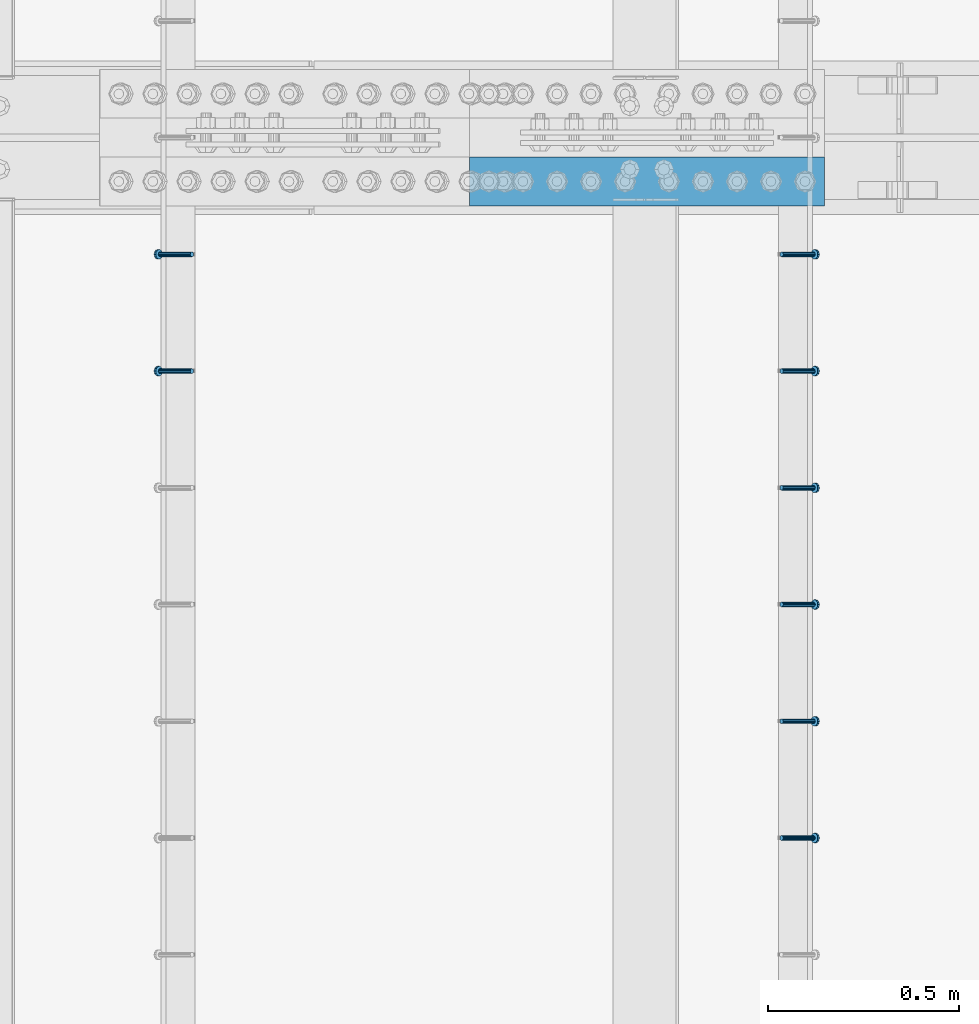
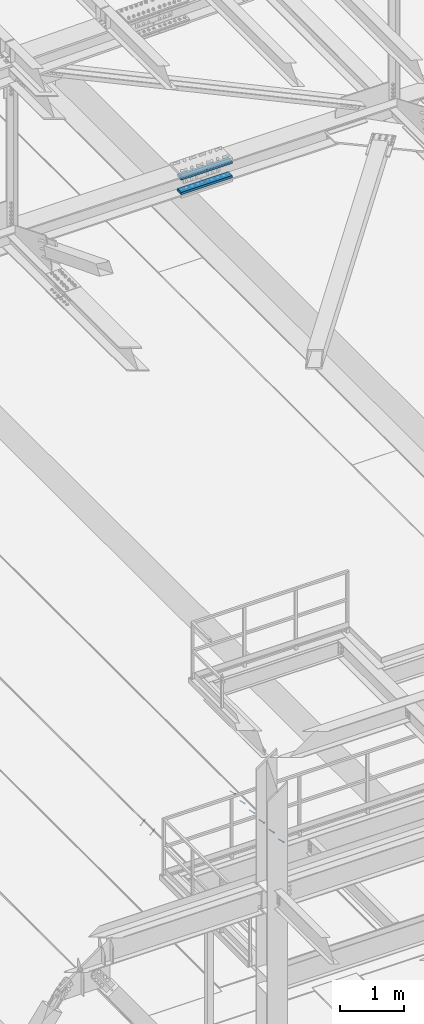
# One storey, part 2229 of 3843: 8 members, 2 beams, 3 elements without a shape of their own.
"""IFC2X3 building model written with IfcOpenShell, lengths in millimetres."""

from ifc_helpers import new_model, si_unit, frame, origin_with_axes, place, context, subcontext, project, spatial, faceted_brep, material, type_object, element, aggregate, save


model = new_model("IFC2X3")

# Units and contexts
model_context = context("Model", 3, precision=1e-05, world=origin_with_axes())
body_context = subcontext(model_context, "Body", "Model", "MODEL_VIEW")
ifc_project = project(units=[si_unit("LENGTHUNIT", "METRE", prefix="MILLI"), si_unit("AREAUNIT", "SQUARE_METRE"), si_unit("VOLUMEUNIT", "CUBIC_METRE"), si_unit("MASSUNIT", "GRAM", prefix="KILO"), si_unit("TIMEUNIT", "SECOND"), si_unit("PLANEANGLEUNIT", "RADIAN"), si_unit("SOLIDANGLEUNIT", "STERADIAN"), si_unit("THERMODYNAMICTEMPERATUREUNIT", "DEGREE_CELSIUS"), si_unit("LUMINOUSINTENSITYUNIT", "LUMEN")], contexts=[model_context])

# Site, building, storey
site_placement = place(None, origin_with_axes())
site = spatial("IfcSite", under=ifc_project, at=site_placement, CompositionType="ELEMENT")
building_placement = place(site_placement, origin_with_axes())
building = spatial("IfcBuilding", under=site, at=building_placement, Name="Undefined", CompositionType="ELEMENT")
storey_placement = place(building_placement, origin_with_axes())
storey = spatial("IfcBuildingStorey", under=building, at=storey_placement, Name="Undefined", CompositionType="ELEMENT", Elevation=0.0)

# Assembly, members
assembly_1_placement = place(storey_placement, origin_with_axes())
assembly_1 = element("IfcElementAssembly", 1, at=assembly_1_placement, inside=storey, Name="EMBED_ANGLE", AssemblyPlace="NOTDEFINED", PredefinedType="RIGID_FRAME")
ifc_material_1 = material(Name="STEEL/A108")
member_type = type_object("IfcMemberType", PredefinedType="NOTDEFINED")
member_1_placement = place(assembly_1_placement, frame((52815.2360419921, 32016.826609375, 30446.6625), z_axis=(0.0, 1.0, 0.0), x_axis=(0.707106781186548, 0.0, -0.707106781186548)))
member_1 = element("IfcMember", 2, at=member_1_placement, type_object=member_type, material=ifc_material_1, Name="HEADED STUD ANCHOR", context=body_context, shape_type="Brep", body=[
    faceted_brep([(7.27595761418343e-12, -3.18000006675175, 5.5), (0.0, -5.49999999998363, 3.1800000667572), (118.110000000976, -5.49999999999091, 3.1800000667572), (118.110000000983, -3.18000006675175, 5.5), (0.0, -6.3499999046162, 0.0), (118.110000000968, -6.34999990461256, 0.0), (0.0, -5.49999999998363, -3.1800000667572), (118.110000000976, -5.49999999999091, -3.1800000667572), (7.27595761418343e-12, -3.18000006675175, -5.5), (118.110000000983, -3.18000006675175, -5.5), (7.27595761418343e-12, -1.81898940354586e-12, -6.34999990463257), (118.110000000968, -1.81898940354586e-12, -6.34999990463257), (0.0, 3.18000006675175, -5.5), (118.110000000968, 3.18000006674811, -5.5), (7.27595761418343e-12, 5.49999999998363, -3.1800000667572), (118.110000000983, 5.49999999998363, -3.1800000667572), (7.27595761418343e-12, 6.3499999046162, 0.0), (118.110000000976, 6.34999990461256, 0.0), (7.27595761418343e-12, 5.49999999998363, 3.1800000667572), (118.110000000983, 5.49999999998363, 3.1800000667572), (0.0, 3.18000006675175, 5.5), (118.110000000968, 3.18000006674811, 5.5), (7.27595761418343e-12, -1.81898940354586e-12, 6.34999990463257), (118.110000000968, -1.81898940354586e-12, 6.34999990463257), (120.650000000991, -10.9899997710909, 6.34999990463257), (120.650000000998, -6.34000015257152, 10.9899997711182), (120.650000000991, -12.6999998092379, 0.0), (120.650000000991, -10.9899997710909, -6.34999990463257), (120.650000000998, -6.34000015257152, -10.9899997711182), (120.650000000991, -1.81898940354586e-12, -12.6899995803833), (120.650000000991, 6.34000015257152, -10.9899997711182), (120.650000000998, 10.9899997710909, -6.34999990463257), (120.650000000991, 12.6999998092342, 0.0), (120.650000000998, 10.9899997710909, 6.34999990463257), (120.650000000991, 6.34000015257152, 10.9899997711182), (120.650000000991, -1.81898940354586e-12, 12.6899995803833), (127.000000001048, -10.9899997710945, 6.34999990463257), (127.000000001048, -6.34000015257152, 10.9899997711182), (127.000000001048, -12.6999998092342, 0.0), (127.000000001048, -10.9899997710945, -6.34999990463257), (127.000000001048, -6.34000015257152, -10.9899997711182), (127.000000001048, 1.81898940354586e-12, -12.6899995803833), (127.000000001048, 6.34000015256788, -10.9899997711182), (127.000000001048, 10.9899997710909, -6.34999990463257), (127.000000001048, 12.6999998092379, 0.0), (127.000000001048, 10.9899997710909, 6.34999990463257), (127.000000001048, 6.34000015256788, 10.9899997711182), (127.000000001048, 1.81898940354586e-12, 12.6899995803833)], [[[0, 1, 2, 3]], [[1, 4, 5, 2]], [[4, 6, 7, 5]], [[6, 8, 9, 7]], [[8, 10, 11, 9]], [[10, 12, 13, 11]], [[12, 14, 15, 13]], [[14, 16, 17, 15]], [[16, 18, 19, 17]], [[18, 20, 21, 19]], [[20, 22, 23, 21]], [[22, 0, 3, 23]], [[22, 20, 18, 16, 14, 12, 10, 8, 6, 4, 1, 0]], [[3, 2, 24, 25]], [[2, 5, 26, 24]], [[5, 7, 27, 26]], [[7, 9, 28, 27]], [[9, 11, 29, 28]], [[11, 13, 30, 29]], [[13, 15, 31, 30]], [[15, 17, 32, 31]], [[17, 19, 33, 32]], [[19, 21, 34, 33]], [[21, 23, 35, 34]], [[23, 3, 25, 35]], [[25, 24, 36, 37]], [[24, 26, 38, 36]], [[26, 27, 39, 38]], [[27, 28, 40, 39]], [[28, 29, 41, 40]], [[29, 30, 42, 41]], [[30, 31, 43, 42]], [[31, 32, 44, 43]], [[32, 33, 45, 44]], [[33, 34, 46, 45]], [[34, 35, 47, 46]], [[35, 25, 37, 47]], [[38, 39, 40, 41, 42, 43, 44, 45, 46, 47, 37, 36]]]),
])
member_2_placement = place(assembly_1_placement, frame((52815.2360419921, 32321.626609375, 30446.6625), z_axis=(0.0, 1.0, 0.0), x_axis=(0.707106781186548, 0.0, -0.707106781186548)))
member_2 = element("IfcMember", 3, at=member_2_placement, type_object=member_type, material=ifc_material_1, Name="HEADED STUD ANCHOR", context=body_context, shape_type="Brep", body=[
    faceted_brep([(7.27595761418343e-12, -3.18000006675175, 5.5), (0.0, -5.49999999998363, 3.1800000667572), (118.110000000976, -5.49999999999091, 3.1800000667572), (118.110000000983, -3.18000006675175, 5.5), (0.0, -6.3499999046162, 0.0), (118.110000000968, -6.34999990461256, 0.0), (0.0, -5.49999999998363, -3.1800000667572), (118.110000000976, -5.49999999999091, -3.1800000667572), (7.27595761418343e-12, -3.18000006675175, -5.5), (118.110000000983, -3.18000006675175, -5.5), (7.27595761418343e-12, -1.81898940354586e-12, -6.34999990463257), (118.110000000968, -1.81898940354586e-12, -6.34999990463257), (0.0, 3.18000006675175, -5.5), (118.110000000968, 3.18000006674811, -5.5), (7.27595761418343e-12, 5.49999999998363, -3.1800000667572), (118.110000000983, 5.49999999998363, -3.1800000667572), (7.27595761418343e-12, 6.3499999046162, 0.0), (118.110000000976, 6.34999990461256, 0.0), (7.27595761418343e-12, 5.49999999998363, 3.1800000667572), (118.110000000983, 5.49999999998363, 3.1800000667572), (0.0, 3.18000006675175, 5.5), (118.110000000968, 3.18000006674811, 5.5), (7.27595761418343e-12, -1.81898940354586e-12, 6.34999990463257), (118.110000000968, -1.81898940354586e-12, 6.34999990463257), (120.650000000991, -10.9899997710909, 6.34999990463257), (120.650000000998, -6.34000015257152, 10.9899997711182), (120.650000000991, -12.6999998092379, 0.0), (120.650000000991, -10.9899997710909, -6.34999990463257), (120.650000000998, -6.34000015257152, -10.9899997711182), (120.650000000991, -1.81898940354586e-12, -12.6899995803833), (120.650000000991, 6.34000015257152, -10.9899997711182), (120.650000000998, 10.9899997710909, -6.34999990463257), (120.650000000991, 12.6999998092342, 0.0), (120.650000000998, 10.9899997710909, 6.34999990463257), (120.650000000991, 6.34000015257152, 10.9899997711182), (120.650000000991, -1.81898940354586e-12, 12.6899995803833), (127.000000001048, -10.9899997710945, 6.34999990463257), (127.000000001048, -6.34000015257152, 10.9899997711182), (127.000000001048, -12.6999998092342, 0.0), (127.000000001048, -10.9899997710945, -6.34999990463257), (127.000000001048, -6.34000015257152, -10.9899997711182), (127.000000001048, 1.81898940354586e-12, -12.6899995803833), (127.000000001048, 6.34000015256788, -10.9899997711182), (127.000000001048, 10.9899997710909, -6.34999990463257), (127.000000001048, 12.6999998092379, 0.0), (127.000000001048, 10.9899997710909, 6.34999990463257), (127.000000001048, 6.34000015256788, 10.9899997711182), (127.000000001048, 1.81898940354586e-12, 12.6899995803833)], [[[0, 1, 2, 3]], [[1, 4, 5, 2]], [[4, 6, 7, 5]], [[6, 8, 9, 7]], [[8, 10, 11, 9]], [[10, 12, 13, 11]], [[12, 14, 15, 13]], [[14, 16, 17, 15]], [[16, 18, 19, 17]], [[18, 20, 21, 19]], [[20, 22, 23, 21]], [[22, 0, 3, 23]], [[22, 20, 18, 16, 14, 12, 10, 8, 6, 4, 1, 0]], [[3, 2, 24, 25]], [[2, 5, 26, 24]], [[5, 7, 27, 26]], [[7, 9, 28, 27]], [[9, 11, 29, 28]], [[11, 13, 30, 29]], [[13, 15, 31, 30]], [[15, 17, 32, 31]], [[17, 19, 33, 32]], [[19, 21, 34, 33]], [[21, 23, 35, 34]], [[23, 3, 25, 35]], [[25, 24, 36, 37]], [[24, 26, 38, 36]], [[26, 27, 39, 38]], [[27, 28, 40, 39]], [[28, 29, 41, 40]], [[29, 30, 42, 41]], [[30, 31, 43, 42]], [[31, 32, 44, 43]], [[32, 33, 45, 44]], [[33, 34, 46, 45]], [[34, 35, 47, 46]], [[35, 25, 37, 47]], [[38, 39, 40, 41, 42, 43, 44, 45, 46, 47, 37, 36]]]),
])
member_3_placement = place(assembly_1_placement, frame((52815.2360419921, 32626.426609375, 30446.6625), z_axis=(0.0, 1.0, 0.0), x_axis=(0.707106781186548, 0.0, -0.707106781186548)))
member_3 = element("IfcMember", 4, at=member_3_placement, type_object=member_type, material=ifc_material_1, Name="HEADED STUD ANCHOR", context=body_context, shape_type="Brep", body=[
    faceted_brep([(7.27595761418343e-12, -3.18000006675175, 5.5), (0.0, -5.49999999998363, 3.1800000667572), (118.110000000976, -5.49999999999091, 3.1800000667572), (118.110000000983, -3.18000006675175, 5.5), (0.0, -6.3499999046162, 0.0), (118.110000000968, -6.34999990461256, 0.0), (0.0, -5.49999999998363, -3.1800000667572), (118.110000000976, -5.49999999999091, -3.1800000667572), (7.27595761418343e-12, -3.18000006675175, -5.5), (118.110000000983, -3.18000006675175, -5.5), (7.27595761418343e-12, -1.81898940354586e-12, -6.34999990463257), (118.110000000968, -1.81898940354586e-12, -6.34999990463257), (0.0, 3.18000006675175, -5.5), (118.110000000968, 3.18000006674811, -5.5), (7.27595761418343e-12, 5.49999999998363, -3.1800000667572), (118.110000000983, 5.49999999998363, -3.1800000667572), (7.27595761418343e-12, 6.3499999046162, 0.0), (118.110000000976, 6.34999990461256, 0.0), (7.27595761418343e-12, 5.49999999998363, 3.1800000667572), (118.110000000983, 5.49999999998363, 3.1800000667572), (0.0, 3.18000006675175, 5.5), (118.110000000968, 3.18000006674811, 5.5), (7.27595761418343e-12, -1.81898940354586e-12, 6.34999990463257), (118.110000000968, -1.81898940354586e-12, 6.34999990463257), (120.650000000991, -10.9899997710909, 6.34999990463257), (120.650000000998, -6.34000015257152, 10.9899997711182), (120.650000000991, -12.6999998092379, 0.0), (120.650000000991, -10.9899997710909, -6.34999990463257), (120.650000000998, -6.34000015257152, -10.9899997711182), (120.650000000991, -1.81898940354586e-12, -12.6899995803833), (120.650000000991, 6.34000015257152, -10.9899997711182), (120.650000000998, 10.9899997710909, -6.34999990463257), (120.650000000991, 12.6999998092342, 0.0), (120.650000000998, 10.9899997710909, 6.34999990463257), (120.650000000991, 6.34000015257152, 10.9899997711182), (120.650000000991, -1.81898940354586e-12, 12.6899995803833), (127.000000001048, -10.9899997710945, 6.34999990463257), (127.000000001048, -6.34000015257152, 10.9899997711182), (127.000000001048, -12.6999998092342, 0.0), (127.000000001048, -10.9899997710945, -6.34999990463257), (127.000000001048, -6.34000015257152, -10.9899997711182), (127.000000001048, 1.81898940354586e-12, -12.6899995803833), (127.000000001048, 6.34000015256788, -10.9899997711182), (127.000000001048, 10.9899997710909, -6.34999990463257), (127.000000001048, 12.6999998092379, 0.0), (127.000000001048, 10.9899997710909, 6.34999990463257), (127.000000001048, 6.34000015256788, 10.9899997711182), (127.000000001048, 1.81898940354586e-12, 12.6899995803833)], [[[0, 1, 2, 3]], [[1, 4, 5, 2]], [[4, 6, 7, 5]], [[6, 8, 9, 7]], [[8, 10, 11, 9]], [[10, 12, 13, 11]], [[12, 14, 15, 13]], [[14, 16, 17, 15]], [[16, 18, 19, 17]], [[18, 20, 21, 19]], [[20, 22, 23, 21]], [[22, 0, 3, 23]], [[22, 20, 18, 16, 14, 12, 10, 8, 6, 4, 1, 0]], [[3, 2, 24, 25]], [[2, 5, 26, 24]], [[5, 7, 27, 26]], [[7, 9, 28, 27]], [[9, 11, 29, 28]], [[11, 13, 30, 29]], [[13, 15, 31, 30]], [[15, 17, 32, 31]], [[17, 19, 33, 32]], [[19, 21, 34, 33]], [[21, 23, 35, 34]], [[23, 3, 25, 35]], [[25, 24, 36, 37]], [[24, 26, 38, 36]], [[26, 27, 39, 38]], [[27, 28, 40, 39]], [[28, 29, 41, 40]], [[29, 30, 42, 41]], [[30, 31, 43, 42]], [[31, 32, 44, 43]], [[32, 33, 45, 44]], [[33, 34, 46, 45]], [[34, 35, 47, 46]], [[35, 25, 37, 47]], [[38, 39, 40, 41, 42, 43, 44, 45, 46, 47, 37, 36]]]),
])
member_4_placement = place(assembly_1_placement, frame((52815.2360419921, 32931.226609375, 30446.6625), z_axis=(0.0, 1.0, 0.0), x_axis=(0.707106781186548, 0.0, -0.707106781186548)))
member_4 = element("IfcMember", 5, at=member_4_placement, type_object=member_type, material=ifc_material_1, Name="HEADED STUD ANCHOR", context=body_context, shape_type="Brep", body=[
    faceted_brep([(7.27595761418343e-12, -3.18000006675175, 5.5), (0.0, -5.49999999998363, 3.1800000667572), (118.110000000976, -5.49999999999091, 3.1800000667572), (118.110000000983, -3.18000006675175, 5.5), (0.0, -6.3499999046162, 0.0), (118.110000000968, -6.34999990461256, 0.0), (0.0, -5.49999999998363, -3.1800000667572), (118.110000000976, -5.49999999999091, -3.1800000667572), (7.27595761418343e-12, -3.18000006675175, -5.5), (118.110000000983, -3.18000006675175, -5.5), (7.27595761418343e-12, -1.81898940354586e-12, -6.34999990463257), (118.110000000968, -1.81898940354586e-12, -6.34999990463257), (0.0, 3.18000006675175, -5.5), (118.110000000968, 3.18000006674811, -5.5), (7.27595761418343e-12, 5.49999999998363, -3.1800000667572), (118.110000000983, 5.49999999998363, -3.1800000667572), (7.27595761418343e-12, 6.3499999046162, 0.0), (118.110000000976, 6.34999990461256, 0.0), (7.27595761418343e-12, 5.49999999998363, 3.1800000667572), (118.110000000983, 5.49999999998363, 3.1800000667572), (0.0, 3.18000006675175, 5.5), (118.110000000968, 3.18000006674811, 5.5), (7.27595761418343e-12, -1.81898940354586e-12, 6.34999990463257), (118.110000000968, -1.81898940354586e-12, 6.34999990463257), (120.650000000991, -10.9899997710909, 6.34999990463257), (120.650000000998, -6.34000015257152, 10.9899997711182), (120.650000000991, -12.6999998092379, 0.0), (120.650000000991, -10.9899997710909, -6.34999990463257), (120.650000000998, -6.34000015257152, -10.9899997711182), (120.650000000991, -1.81898940354586e-12, -12.6899995803833), (120.650000000991, 6.34000015257152, -10.9899997711182), (120.650000000998, 10.9899997710909, -6.34999990463257), (120.650000000991, 12.6999998092342, 0.0), (120.650000000998, 10.9899997710909, 6.34999990463257), (120.650000000991, 6.34000015257152, 10.9899997711182), (120.650000000991, -1.81898940354586e-12, 12.6899995803833), (127.000000001048, -10.9899997710945, 6.34999990463257), (127.000000001048, -6.34000015257152, 10.9899997711182), (127.000000001048, -12.6999998092342, 0.0), (127.000000001048, -10.9899997710945, -6.34999990463257), (127.000000001048, -6.34000015257152, -10.9899997711182), (127.000000001048, 1.81898940354586e-12, -12.6899995803833), (127.000000001048, 6.34000015256788, -10.9899997711182), (127.000000001048, 10.9899997710909, -6.34999990463257), (127.000000001048, 12.6999998092379, 0.0), (127.000000001048, 10.9899997710909, 6.34999990463257), (127.000000001048, 6.34000015256788, 10.9899997711182), (127.000000001048, 1.81898940354586e-12, 12.6899995803833)], [[[0, 1, 2, 3]], [[1, 4, 5, 2]], [[4, 6, 7, 5]], [[6, 8, 9, 7]], [[8, 10, 11, 9]], [[10, 12, 13, 11]], [[12, 14, 15, 13]], [[14, 16, 17, 15]], [[16, 18, 19, 17]], [[18, 20, 21, 19]], [[20, 22, 23, 21]], [[22, 0, 3, 23]], [[22, 20, 18, 16, 14, 12, 10, 8, 6, 4, 1, 0]], [[3, 2, 24, 25]], [[2, 5, 26, 24]], [[5, 7, 27, 26]], [[7, 9, 28, 27]], [[9, 11, 29, 28]], [[11, 13, 30, 29]], [[13, 15, 31, 30]], [[15, 17, 32, 31]], [[17, 19, 33, 32]], [[19, 21, 34, 33]], [[21, 23, 35, 34]], [[23, 3, 25, 35]], [[25, 24, 36, 37]], [[24, 26, 38, 36]], [[26, 27, 39, 38]], [[27, 28, 40, 39]], [[28, 29, 41, 40]], [[29, 30, 42, 41]], [[30, 31, 43, 42]], [[31, 32, 44, 43]], [[32, 33, 45, 44]], [[33, 34, 46, 45]], [[34, 35, 47, 46]], [[35, 25, 37, 47]], [[38, 39, 40, 41, 42, 43, 44, 45, 46, 47, 37, 36]]]),
])
member_5_placement = place(assembly_1_placement, frame((52815.2360419921, 33236.026609375, 30446.6625), z_axis=(0.0, 1.0, 0.0), x_axis=(0.707106781186548, 0.0, -0.707106781186548)))
member_5 = element("IfcMember", 6, at=member_5_placement, type_object=member_type, material=ifc_material_1, Name="HEADED STUD ANCHOR", context=body_context, shape_type="Brep", body=[
    faceted_brep([(7.27595761418343e-12, -3.18000006675175, 5.5), (0.0, -5.49999999998363, 3.1800000667572), (118.110000000976, -5.49999999999091, 3.1800000667572), (118.110000000983, -3.18000006675175, 5.5), (0.0, -6.3499999046162, 0.0), (118.110000000968, -6.34999990461256, 0.0), (0.0, -5.49999999998363, -3.1800000667572), (118.110000000976, -5.49999999999091, -3.1800000667572), (7.27595761418343e-12, -3.18000006675175, -5.5), (118.110000000983, -3.18000006675175, -5.5), (7.27595761418343e-12, -1.81898940354586e-12, -6.34999990463257), (118.110000000968, -1.81898940354586e-12, -6.34999990463257), (0.0, 3.18000006675175, -5.5), (118.110000000968, 3.18000006674811, -5.5), (7.27595761418343e-12, 5.49999999998363, -3.1800000667572), (118.110000000983, 5.49999999998363, -3.1800000667572), (7.27595761418343e-12, 6.3499999046162, 0.0), (118.110000000976, 6.34999990461256, 0.0), (7.27595761418343e-12, 5.49999999998363, 3.1800000667572), (118.110000000983, 5.49999999998363, 3.1800000667572), (0.0, 3.18000006675175, 5.5), (118.110000000968, 3.18000006674811, 5.5), (7.27595761418343e-12, -1.81898940354586e-12, 6.34999990463257), (118.110000000968, -1.81898940354586e-12, 6.34999990463257), (120.650000000991, -10.9899997710909, 6.34999990463257), (120.650000000998, -6.34000015257152, 10.9899997711182), (120.650000000991, -12.6999998092379, 0.0), (120.650000000991, -10.9899997710909, -6.34999990463257), (120.650000000998, -6.34000015257152, -10.9899997711182), (120.650000000991, -1.81898940354586e-12, -12.6899995803833), (120.650000000991, 6.34000015257152, -10.9899997711182), (120.650000000998, 10.9899997710909, -6.34999990463257), (120.650000000991, 12.6999998092342, 0.0), (120.650000000998, 10.9899997710909, 6.34999990463257), (120.650000000991, 6.34000015257152, 10.9899997711182), (120.650000000991, -1.81898940354586e-12, 12.6899995803833), (127.000000001048, -10.9899997710945, 6.34999990463257), (127.000000001048, -6.34000015257152, 10.9899997711182), (127.000000001048, -12.6999998092342, 0.0), (127.000000001048, -10.9899997710945, -6.34999990463257), (127.000000001048, -6.34000015257152, -10.9899997711182), (127.000000001048, 1.81898940354586e-12, -12.6899995803833), (127.000000001048, 6.34000015256788, -10.9899997711182), (127.000000001048, 10.9899997710909, -6.34999990463257), (127.000000001048, 12.6999998092379, 0.0), (127.000000001048, 10.9899997710909, 6.34999990463257), (127.000000001048, 6.34000015256788, 10.9899997711182), (127.000000001048, 1.81898940354586e-12, 12.6899995803833)], [[[0, 1, 2, 3]], [[1, 4, 5, 2]], [[4, 6, 7, 5]], [[6, 8, 9, 7]], [[8, 10, 11, 9]], [[10, 12, 13, 11]], [[12, 14, 15, 13]], [[14, 16, 17, 15]], [[16, 18, 19, 17]], [[18, 20, 21, 19]], [[20, 22, 23, 21]], [[22, 0, 3, 23]], [[22, 20, 18, 16, 14, 12, 10, 8, 6, 4, 1, 0]], [[3, 2, 24, 25]], [[2, 5, 26, 24]], [[5, 7, 27, 26]], [[7, 9, 28, 27]], [[9, 11, 29, 28]], [[11, 13, 30, 29]], [[13, 15, 31, 30]], [[15, 17, 32, 31]], [[17, 19, 33, 32]], [[19, 21, 34, 33]], [[21, 23, 35, 34]], [[23, 3, 25, 35]], [[25, 24, 36, 37]], [[24, 26, 38, 36]], [[26, 27, 39, 38]], [[27, 28, 40, 39]], [[28, 29, 41, 40]], [[29, 30, 42, 41]], [[30, 31, 43, 42]], [[31, 32, 44, 43]], [[32, 33, 45, 44]], [[33, 34, 46, 45]], [[34, 35, 47, 46]], [[35, 25, 37, 47]], [[38, 39, 40, 41, 42, 43, 44, 45, 46, 47, 37, 36]]]),
])
member_6_placement = place(assembly_1_placement, frame((52815.2360419921, 33540.826609375, 30446.6625), z_axis=(0.0, 1.0, 0.0), x_axis=(0.707106781186548, 0.0, -0.707106781186548)))
member_6 = element("IfcMember", 7, at=member_6_placement, type_object=member_type, material=ifc_material_1, Name="HEADED STUD ANCHOR", context=body_context, shape_type="Brep", body=[
    faceted_brep([(7.27595761418343e-12, -3.18000006675175, 5.5), (0.0, -5.49999999998363, 3.1800000667572), (118.110000000976, -5.49999999999091, 3.1800000667572), (118.110000000983, -3.18000006675175, 5.5), (0.0, -6.3499999046162, 0.0), (118.110000000968, -6.34999990461256, 0.0), (0.0, -5.49999999998363, -3.1800000667572), (118.110000000976, -5.49999999999091, -3.1800000667572), (7.27595761418343e-12, -3.18000006675175, -5.5), (118.110000000983, -3.18000006675175, -5.5), (7.27595761418343e-12, -1.81898940354586e-12, -6.34999990463257), (118.110000000968, -1.81898940354586e-12, -6.34999990463257), (0.0, 3.18000006675175, -5.5), (118.110000000968, 3.18000006674811, -5.5), (7.27595761418343e-12, 5.49999999998363, -3.1800000667572), (118.110000000983, 5.49999999998363, -3.1800000667572), (7.27595761418343e-12, 6.3499999046162, 0.0), (118.110000000976, 6.34999990461256, 0.0), (7.27595761418343e-12, 5.49999999998363, 3.1800000667572), (118.110000000983, 5.49999999998363, 3.1800000667572), (0.0, 3.18000006675175, 5.5), (118.110000000968, 3.18000006674811, 5.5), (7.27595761418343e-12, -1.81898940354586e-12, 6.34999990463257), (118.110000000968, -1.81898940354586e-12, 6.34999990463257), (120.650000000991, -10.9899997710909, 6.34999990463257), (120.650000000998, -6.34000015257152, 10.9899997711182), (120.650000000991, -12.6999998092379, 0.0), (120.650000000991, -10.9899997710909, -6.34999990463257), (120.650000000998, -6.34000015257152, -10.9899997711182), (120.650000000991, -1.81898940354586e-12, -12.6899995803833), (120.650000000991, 6.34000015257152, -10.9899997711182), (120.650000000998, 10.9899997710909, -6.34999990463257), (120.650000000991, 12.6999998092342, 0.0), (120.650000000998, 10.9899997710909, 6.34999990463257), (120.650000000991, 6.34000015257152, 10.9899997711182), (120.650000000991, -1.81898940354586e-12, 12.6899995803833), (127.000000001048, -10.9899997710945, 6.34999990463257), (127.000000001048, -6.34000015257152, 10.9899997711182), (127.000000001048, -12.6999998092342, 0.0), (127.000000001048, -10.9899997710945, -6.34999990463257), (127.000000001048, -6.34000015257152, -10.9899997711182), (127.000000001048, 1.81898940354586e-12, -12.6899995803833), (127.000000001048, 6.34000015256788, -10.9899997711182), (127.000000001048, 10.9899997710909, -6.34999990463257), (127.000000001048, 12.6999998092379, 0.0), (127.000000001048, 10.9899997710909, 6.34999990463257), (127.000000001048, 6.34000015256788, 10.9899997711182), (127.000000001048, 1.81898940354586e-12, 12.6899995803833)], [[[0, 1, 2, 3]], [[1, 4, 5, 2]], [[4, 6, 7, 5]], [[6, 8, 9, 7]], [[8, 10, 11, 9]], [[10, 12, 13, 11]], [[12, 14, 15, 13]], [[14, 16, 17, 15]], [[16, 18, 19, 17]], [[18, 20, 21, 19]], [[20, 22, 23, 21]], [[22, 0, 3, 23]], [[22, 20, 18, 16, 14, 12, 10, 8, 6, 4, 1, 0]], [[3, 2, 24, 25]], [[2, 5, 26, 24]], [[5, 7, 27, 26]], [[7, 9, 28, 27]], [[9, 11, 29, 28]], [[11, 13, 30, 29]], [[13, 15, 31, 30]], [[15, 17, 32, 31]], [[17, 19, 33, 32]], [[19, 21, 34, 33]], [[21, 23, 35, 34]], [[23, 3, 25, 35]], [[25, 24, 36, 37]], [[24, 26, 38, 36]], [[26, 27, 39, 38]], [[27, 28, 40, 39]], [[28, 29, 41, 40]], [[29, 30, 42, 41]], [[30, 31, 43, 42]], [[31, 32, 44, 43]], [[32, 33, 45, 44]], [[33, 34, 46, 45]], [[34, 35, 47, 46]], [[35, 25, 37, 47]], [[38, 39, 40, 41, 42, 43, 44, 45, 46, 47, 37, 36]]]),
])
aggregate(assembly_1, [member_1, member_2, member_3, member_4, member_5, member_6])

assembly_2_placement = place(storey_placement, origin_with_axes())
assembly_2 = element("IfcElementAssembly", 8, at=assembly_2_placement, inside=storey, Name="EMBED_ANGLE", AssemblyPlace="NOTDEFINED", PredefinedType="RIGID_FRAME")
member_7_placement = place(assembly_2_placement, frame((51275.424484375, 33236.026609375, 30446.6625), z_axis=(0.0, 1.0, 0.0), x_axis=(-0.707106781186548, 0.0, -0.707106781186548)))
member_7 = element("IfcMember", 9, at=member_7_placement, type_object=member_type, material=ifc_material_1, Name="HEADED STUD ANCHOR", context=body_context, shape_type="Brep", body=[
    faceted_brep([(7.27595761418343e-12, -3.18000006675175, 5.5), (0.0, -5.49999999998363, 3.1800000667572), (118.110000000976, -5.49999999999091, 3.1800000667572), (118.110000000983, -3.18000006675175, 5.5), (0.0, -6.3499999046162, 0.0), (118.110000000968, -6.34999990461256, 0.0), (0.0, -5.49999999998363, -3.1800000667572), (118.110000000976, -5.49999999999091, -3.1800000667572), (7.27595761418343e-12, -3.18000006675175, -5.5), (118.110000000983, -3.18000006675175, -5.5), (7.27595761418343e-12, -1.81898940354586e-12, -6.34999990463257), (118.110000000968, -1.81898940354586e-12, -6.34999990463257), (0.0, 3.18000006675175, -5.5), (118.110000000968, 3.18000006674811, -5.5), (7.27595761418343e-12, 5.49999999998363, -3.1800000667572), (118.110000000983, 5.49999999998363, -3.1800000667572), (7.27595761418343e-12, 6.3499999046162, 0.0), (118.110000000976, 6.34999990461256, 0.0), (7.27595761418343e-12, 5.49999999998363, 3.1800000667572), (118.110000000983, 5.49999999998363, 3.1800000667572), (0.0, 3.18000006675175, 5.5), (118.110000000968, 3.18000006674811, 5.5), (7.27595761418343e-12, -1.81898940354586e-12, 6.34999990463257), (118.110000000968, -1.81898940354586e-12, 6.34999990463257), (120.650000000991, -10.9899997710909, 6.34999990463257), (120.650000000998, -6.34000015257152, 10.9899997711182), (120.650000000991, -12.6999998092379, 0.0), (120.650000000991, -10.9899997710909, -6.34999990463257), (120.650000000998, -6.34000015257152, -10.9899997711182), (120.650000000991, -1.81898940354586e-12, -12.6899995803833), (120.650000000991, 6.34000015257152, -10.9899997711182), (120.650000000998, 10.9899997710909, -6.34999990463257), (120.650000000991, 12.6999998092342, 0.0), (120.650000000998, 10.9899997710909, 6.34999990463257), (120.650000000991, 6.34000015257152, 10.9899997711182), (120.650000000991, -1.81898940354586e-12, 12.6899995803833), (127.000000001048, -10.9899997710945, 6.34999990463257), (127.000000001048, -6.34000015257152, 10.9899997711182), (127.000000001048, -12.6999998092342, 0.0), (127.000000001048, -10.9899997710945, -6.34999990463257), (127.000000001048, -6.34000015257152, -10.9899997711182), (127.000000001048, 1.81898940354586e-12, -12.6899995803833), (127.000000001048, 6.34000015256788, -10.9899997711182), (127.000000001048, 10.9899997710909, -6.34999990463257), (127.000000001048, 12.6999998092379, 0.0), (127.000000001048, 10.9899997710909, 6.34999990463257), (127.000000001048, 6.34000015256788, 10.9899997711182), (127.000000001048, 1.81898940354586e-12, 12.6899995803833)], [[[0, 1, 2, 3]], [[1, 4, 5, 2]], [[4, 6, 7, 5]], [[6, 8, 9, 7]], [[8, 10, 11, 9]], [[10, 12, 13, 11]], [[12, 14, 15, 13]], [[14, 16, 17, 15]], [[16, 18, 19, 17]], [[18, 20, 21, 19]], [[20, 22, 23, 21]], [[22, 0, 3, 23]], [[22, 20, 18, 16, 14, 12, 10, 8, 6, 4, 1, 0]], [[3, 2, 24, 25]], [[2, 5, 26, 24]], [[5, 7, 27, 26]], [[7, 9, 28, 27]], [[9, 11, 29, 28]], [[11, 13, 30, 29]], [[13, 15, 31, 30]], [[15, 17, 32, 31]], [[17, 19, 33, 32]], [[19, 21, 34, 33]], [[21, 23, 35, 34]], [[23, 3, 25, 35]], [[25, 24, 36, 37]], [[24, 26, 38, 36]], [[26, 27, 39, 38]], [[27, 28, 40, 39]], [[28, 29, 41, 40]], [[29, 30, 42, 41]], [[30, 31, 43, 42]], [[31, 32, 44, 43]], [[32, 33, 45, 44]], [[33, 34, 46, 45]], [[34, 35, 47, 46]], [[35, 25, 37, 47]], [[38, 39, 40, 41, 42, 43, 44, 45, 46, 47, 37, 36]]]),
])
member_8_placement = place(assembly_2_placement, frame((51275.424484375, 33540.826609375, 30446.6625), z_axis=(0.0, 1.0, 0.0), x_axis=(-0.707106781186548, 0.0, -0.707106781186548)))
member_8 = element("IfcMember", 10, at=member_8_placement, type_object=member_type, material=ifc_material_1, Name="HEADED STUD ANCHOR", context=body_context, shape_type="Brep", body=[
    faceted_brep([(7.27595761418343e-12, -3.18000006675175, 5.5), (0.0, -5.49999999998363, 3.1800000667572), (118.110000000976, -5.49999999999091, 3.1800000667572), (118.110000000983, -3.18000006675175, 5.5), (0.0, -6.3499999046162, 0.0), (118.110000000968, -6.34999990461256, 0.0), (0.0, -5.49999999998363, -3.1800000667572), (118.110000000976, -5.49999999999091, -3.1800000667572), (7.27595761418343e-12, -3.18000006675175, -5.5), (118.110000000983, -3.18000006675175, -5.5), (7.27595761418343e-12, -1.81898940354586e-12, -6.34999990463257), (118.110000000968, -1.81898940354586e-12, -6.34999990463257), (0.0, 3.18000006675175, -5.5), (118.110000000968, 3.18000006674811, -5.5), (7.27595761418343e-12, 5.49999999998363, -3.1800000667572), (118.110000000983, 5.49999999998363, -3.1800000667572), (7.27595761418343e-12, 6.3499999046162, 0.0), (118.110000000976, 6.34999990461256, 0.0), (7.27595761418343e-12, 5.49999999998363, 3.1800000667572), (118.110000000983, 5.49999999998363, 3.1800000667572), (0.0, 3.18000006675175, 5.5), (118.110000000968, 3.18000006674811, 5.5), (7.27595761418343e-12, -1.81898940354586e-12, 6.34999990463257), (118.110000000968, -1.81898940354586e-12, 6.34999990463257), (120.650000000991, -10.9899997710909, 6.34999990463257), (120.650000000998, -6.34000015257152, 10.9899997711182), (120.650000000991, -12.6999998092379, 0.0), (120.650000000991, -10.9899997710909, -6.34999990463257), (120.650000000998, -6.34000015257152, -10.9899997711182), (120.650000000991, -1.81898940354586e-12, -12.6899995803833), (120.650000000991, 6.34000015257152, -10.9899997711182), (120.650000000998, 10.9899997710909, -6.34999990463257), (120.650000000991, 12.6999998092342, 0.0), (120.650000000998, 10.9899997710909, 6.34999990463257), (120.650000000991, 6.34000015257152, 10.9899997711182), (120.650000000991, -1.81898940354586e-12, 12.6899995803833), (127.000000001048, -10.9899997710945, 6.34999990463257), (127.000000001048, -6.34000015257152, 10.9899997711182), (127.000000001048, -12.6999998092342, 0.0), (127.000000001048, -10.9899997710945, -6.34999990463257), (127.000000001048, -6.34000015257152, -10.9899997711182), (127.000000001048, 1.81898940354586e-12, -12.6899995803833), (127.000000001048, 6.34000015256788, -10.9899997711182), (127.000000001048, 10.9899997710909, -6.34999990463257), (127.000000001048, 12.6999998092379, 0.0), (127.000000001048, 10.9899997710909, 6.34999990463257), (127.000000001048, 6.34000015256788, 10.9899997711182), (127.000000001048, 1.81898940354586e-12, 12.6899995803833)], [[[0, 1, 2, 3]], [[1, 4, 5, 2]], [[4, 6, 7, 5]], [[6, 8, 9, 7]], [[8, 10, 11, 9]], [[10, 12, 13, 11]], [[12, 14, 15, 13]], [[14, 16, 17, 15]], [[16, 18, 19, 17]], [[18, 20, 21, 19]], [[20, 22, 23, 21]], [[22, 0, 3, 23]], [[22, 20, 18, 16, 14, 12, 10, 8, 6, 4, 1, 0]], [[3, 2, 24, 25]], [[2, 5, 26, 24]], [[5, 7, 27, 26]], [[7, 9, 28, 27]], [[9, 11, 29, 28]], [[11, 13, 30, 29]], [[13, 15, 31, 30]], [[15, 17, 32, 31]], [[17, 19, 33, 32]], [[19, 21, 34, 33]], [[21, 23, 35, 34]], [[23, 3, 25, 35]], [[25, 24, 36, 37]], [[24, 26, 38, 36]], [[26, 27, 39, 38]], [[27, 28, 40, 39]], [[28, 29, 41, 40]], [[29, 30, 42, 41]], [[30, 31, 43, 42]], [[31, 32, 44, 43]], [[32, 33, 45, 44]], [[33, 34, 46, 45]], [[34, 35, 47, 46]], [[35, 25, 37, 47]], [[38, 39, 40, 41, 42, 43, 44, 45, 46, 47, 37, 36]]]),
])
aggregate(assembly_2, [member_7, member_8])

# Assembly, beams
assembly_3_placement = place(storey_placement, origin_with_axes())
assembly_3 = element("IfcElementAssembly", 11, at=assembly_3_placement, inside=storey, Name="BEAM", AssemblyPlace="NOTDEFINED", PredefinedType="RIGID_FRAME")
ifc_material_2 = material(Name="STEEL/A572-50")
beam_type = type_object("IfcBeamType", PredefinedType="NOTDEFINED")
beam_1_placement = place(assembly_3_placement, frame((52927.3166288765, 33731.2, 42116.3321457606), z_axis=(0.0, -1.0, 0.0), x_axis=(-0.999999883445314, 0.0, -0.000482814000210543)))
beam_1 = element("IfcBeam", 12, at=beam_1_placement, type_object=beam_type, material=ifc_material_2, Name="PLATE", context=body_context, shape_type="Brep", body=[
    faceted_brep([(-7.27595761418343e-11, 22.2250000000786, -63.5), (-7.27595761418343e-11, 22.2250000000786, 63.5), (927.099999951592, 22.2250000031054, 63.5), (927.099999951592, 22.2250000031054, -63.5), (6.54836185276508e-11, -22.2250000000713, 63.5), (927.099999951744, -22.2249999970372, 63.5), (6.54836185276508e-11, -22.2250000000713, -63.5), (927.099999951744, -22.2249999970372, -63.5)], [[[0, 1, 2, 3]], [[1, 4, 5, 2]], [[4, 6, 7, 5]], [[6, 0, 3, 7]], [[5, 7, 3, 2]], [[6, 4, 1, 0]]]),
])
beam_2_placement = place(assembly_3_placement, frame((52927.1832633038, 33731.2, 42392.5571135293), z_axis=(0.0, -1.0, 0.0), x_axis=(-0.999999883445314, 0.0, -0.000482814000210543)))
beam_2 = element("IfcBeam", 13, at=beam_2_placement, type_object=beam_type, material=ifc_material_2, Name="PLATE", context=body_context, shape_type="Brep", body=[
    faceted_brep([(-7.27595761418343e-11, 22.2250000000786, -63.5), (-7.27595761418343e-11, 22.2250000000786, 63.5), (927.099999951592, 22.2250000031054, 63.5), (927.099999951592, 22.2250000031054, -63.5), (6.54836185276508e-11, -22.2250000000713, 63.5), (927.099999951744, -22.2249999970372, 63.5), (6.54836185276508e-11, -22.2250000000713, -63.5), (927.099999951744, -22.2249999970372, -63.5)], [[[0, 1, 2, 3]], [[1, 4, 5, 2]], [[4, 6, 7, 5]], [[6, 0, 3, 7]], [[5, 7, 3, 2]], [[6, 4, 1, 0]]]),
])
aggregate(assembly_3, [beam_1, beam_2])

save(model, "model.ifc")
